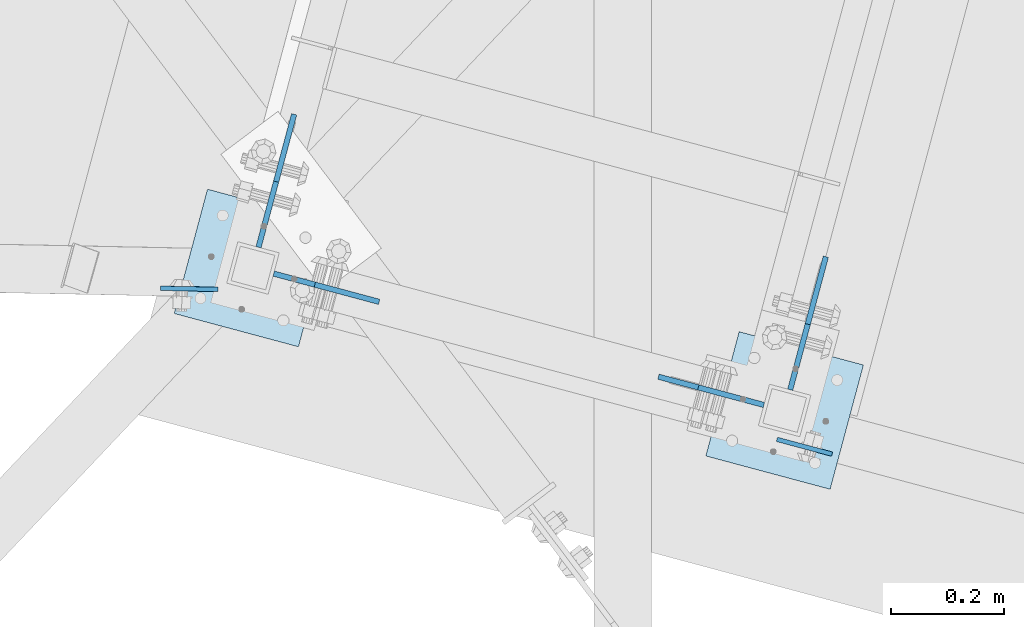
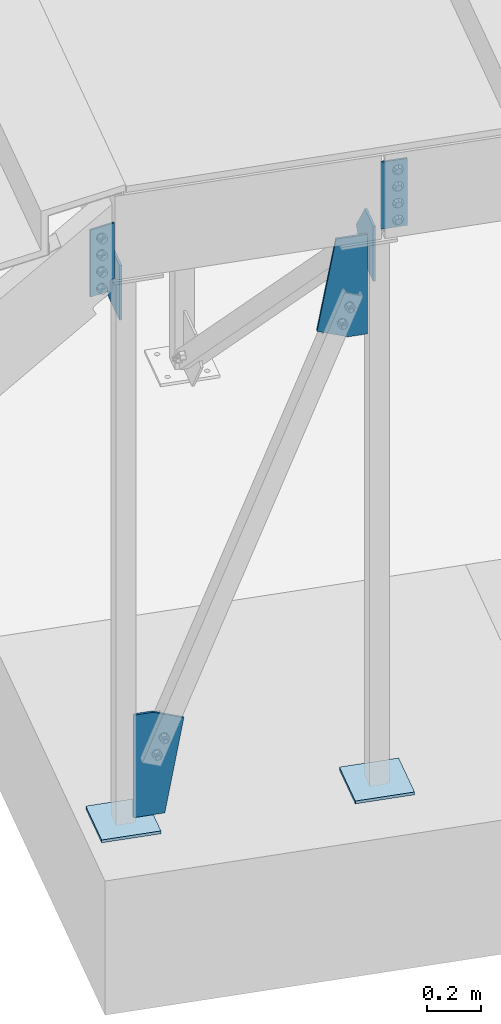
# One storey, part 1681 of 1763: 8 plates, 3 elements without a shape of their own.
"""IFC2X3 building model written with IfcOpenShell, lengths in millimetres."""

from ifc_helpers import new_model, si_unit, frame, origin_with_axes, place, context, subcontext, project, spatial, faceted_brep, material, type_object, element, aggregate, save


model = new_model("IFC2X3")

# Units and contexts
model_context = context("Model", 3, precision=1e-05, world=origin_with_axes())
body_context = subcontext(model_context, "Body", "Model", "MODEL_VIEW")
ifc_project = project(units=[si_unit("LENGTHUNIT", "METRE", prefix="MILLI"), si_unit("AREAUNIT", "SQUARE_METRE"), si_unit("VOLUMEUNIT", "CUBIC_METRE"), si_unit("MASSUNIT", "GRAM", prefix="KILO"), si_unit("TIMEUNIT", "SECOND"), si_unit("PLANEANGLEUNIT", "RADIAN"), si_unit("SOLIDANGLEUNIT", "STERADIAN"), si_unit("THERMODYNAMICTEMPERATUREUNIT", "DEGREE_CELSIUS"), si_unit("LUMINOUSINTENSITYUNIT", "LUMEN")], contexts=[model_context])

# Site, building, storey
site_placement = place(None, origin_with_axes())
site = spatial("IfcSite", under=ifc_project, at=site_placement, CompositionType="ELEMENT")
building_placement = place(site_placement, origin_with_axes())
building = spatial("IfcBuilding", under=site, at=building_placement, Name="Undefined", CompositionType="ELEMENT")
storey_placement = place(building_placement, origin_with_axes())
storey = spatial("IfcBuildingStorey", under=building, at=storey_placement, Name="Undefined", CompositionType="ELEMENT", Elevation=0.0)

# Assembly, plates
assembly_1_placement = place(storey_placement, origin_with_axes())
assembly_1 = element("IfcElementAssembly", 1, at=assembly_1_placement, inside=storey, Name="FRAME", AssemblyPlace="NOTDEFINED", PredefinedType="RIGID_FRAME")
ifc_material = material(Name="STEEL/A36")
plate_type_1 = type_object("IfcPlateType", PredefinedType="NOTDEFINED")
plate_1_placement = place(assembly_1_placement, frame((-27414.7858049951, 60238.992412548, 2590.80000029845), z_axis=(0.965913267114843, -0.258865912030785, 0.0), x_axis=(0.0, 0.0, -1.0)))
plate_1 = element("IfcPlate", 2, at=plate_1_placement, type_object=plate_type_1, material=ifc_material, Name="PLATE", context=body_context, shape_type="Brep", body=[
    faceted_brep([(0.0, -3.96900000000096, 0.0), (-1.18234311230481e-11, -3.96900000000096, 101.599998474121), (-1.18234311230481e-11, 3.96900000000096, 101.599998474121), (0.0, 3.96900000000096, 0.0), (304.799987792969, -3.96900000000096, 101.599998474121), (304.799987792969, 3.96900000000096, 101.599998474121), (304.799987792969, -3.96900000000096, -3.63797880709171e-11), (304.799987792969, 3.96900000000096, -3.63797880709171e-11)], [[[0, 1, 2, 3]], [[1, 4, 5, 2]], [[4, 6, 7, 5]], [[6, 0, 3, 7]], [[5, 7, 3, 2]], [[6, 4, 1, 0]]]),
])
plate_type_2 = type_object("IfcPlateType", PredefinedType="NOTDEFINED")
plate_2_placement = place(assembly_1_placement, frame((-28407.7357650568, 60505.3834172894, 2502.81193964552), z_axis=(-0.999800136337928, 0.0199919170066424, -0.000103116735640924), x_axis=(0.000111453000032564, 0.000415868000126109, -0.999999907316013)))
plate_2 = element("IfcPlate", 3, at=plate_2_placement, type_object=plate_type_2, material=ifc_material, Name="PLATE", context=body_context, shape_type="Brep", body=[
    faceted_brep([(254.931486313912, -3.96899999968446, 3.09228198602796e-10), (254.931020348674, 3.96900000030291, 3.20142135024071e-10), (254.908537894189, 3.96900000033202, 12.5064842653228), (254.909003857889, -3.9689999996699, 12.5064851036404), (255.387677638546, 3.96900000033929, 14.9377382974162), (255.388143602246, -3.96899999966263, 14.9377391357375), (256.760868400506, 3.96900000033929, 17.0004836040862), (256.761334364206, -3.96899999965535, 17.0004844424075), (258.818991804242, 3.96900000034657, 18.3805919809965), (258.819457767941, -3.96899999964808, 18.3805928193142), (261.248623498701, 3.96900000034657, 18.8678915931378), (261.249089462401, -3.9689999996408, 18.8678924314554), (304.799987792991, -3.96899999959714, 18.935818548016), (304.799987792992, 3.96900000040478, 18.9358184364428), (0.0, -3.96900000000096, 0.0), (-4.54747350886464e-13, -3.96899999978632, 101.980705261267), (-4.54747350886464e-13, 3.9690000002156, 101.980705261274), (0.0, 3.96900000000096, 0.0), (304.799987793001, -3.96899999941525, 101.980705261667), (304.799987793002, 3.96900000058668, 101.980705261682)], [[[0, 1, 2, 3]], [[3, 2, 4, 5]], [[5, 4, 6, 7]], [[7, 6, 8, 9]], [[9, 8, 10, 11]], [[12, 11, 10, 13]], [[14, 15, 16, 17]], [[15, 18, 19, 16]], [[19, 18, 12, 13]], [[8, 6, 4, 2, 1, 17, 16, 19, 13, 10]], [[14, 17, 1, 0]], [[18, 15, 14, 0, 3, 5, 7, 9, 11, 12]]]),
])
aggregate(assembly_1, [plate_1, plate_2])

# Assembly, plate
assembly_2_placement = place(storey_placement, origin_with_axes())
assembly_2 = element("IfcElementAssembly", 4, at=assembly_2_placement, inside=storey, Name="COLUMN", AssemblyPlace="NOTDEFINED", PredefinedType="RIGID_FRAME")
plate_type_3 = type_object("IfcPlateType", PredefinedType="NOTDEFINED")
plate_3_placement = place(assembly_2_placement, frame((-28485.5584110489, 60462.6258543711, -260.350000028325), z_axis=(0.258819045079128, 0.965925826295336, 0.0), x_axis=(0.965925826295336, -0.25881904507913, 0.0)))
plate_3 = element("IfcPlate", 5, at=plate_3_placement, type_object=plate_type_3, material=ifc_material, Name="PLATE", context=body_context, shape_type="Brep", body=[
    faceted_brep([(0.0, -6.34999999999491, 1.45519152283669e-11), (0.0, -6.35000000001855, 228.600006104178), (0.0, 6.34999999996944, 228.600006104134), (0.0, 6.34999999999491, -2.91038304567337e-11), (228.600006103363, -6.34999999999999, 228.600006104673), (228.600006103363, 6.35000000000002, 228.600006104673), (228.600006103565, -6.34999999936554, -7.49423634260893e-10), (228.600006103557, 6.35000000064611, -7.13043846189976e-10)], [[[0, 1, 2, 3]], [[1, 4, 5, 2]], [[4, 6, 7, 5]], [[6, 0, 3, 7]], [[5, 7, 3, 2]], [[6, 4, 1, 0]]]),
])

# Assembly, plates
assembly_3_placement = place(storey_placement, origin_with_axes())
assembly_3 = element("IfcElementAssembly", 6, at=assembly_3_placement, inside=storey, Name="COLUMN", AssemblyPlace="NOTDEFINED", PredefinedType="RIGID_FRAME")
plate_4_placement = place(assembly_3_placement, frame((-27540.9918271409, 60209.4808790024, -260.350000028323), z_axis=(0.258819045079128, 0.965925826295336, 0.0), x_axis=(0.965925826295336, -0.25881904507913, 0.0)))
plate_4 = element("IfcPlate", 7, at=plate_4_placement, type_object=plate_type_3, material=ifc_material, Name="PLATE", context=body_context, shape_type="Brep", body=[
    faceted_brep([(0.0, -6.34999999999491, 1.45519152283669e-11), (0.0, -6.35000000001855, 228.600006104178), (0.0, 6.34999999996944, 228.600006104134), (0.0, 6.34999999999491, -2.91038304567337e-11), (228.600006103363, -6.34999999999999, 228.600006104673), (228.600006103363, 6.35000000000002, 228.600006104673), (228.600006103565, -6.34999999936554, -7.49423634260893e-10), (228.600006103557, 6.35000000064611, -7.13043846189976e-10)], [[[0, 1, 2, 3]], [[1, 4, 5, 2]], [[4, 6, 7, 5]], [[6, 0, 3, 7]], [[5, 7, 3, 2]], [[6, 4, 1, 0]]]),
])
plate_type_4 = type_object("IfcPlateType", PredefinedType="NOTDEFINED")
plate_5_placement = place(assembly_3_placement, frame((-27391.1407206985, 60327.1044859432, 1985.92065652224), z_axis=(0.25886591203079, 0.965913267114842, 0.0), x_axis=(0.0, 0.0, 1.0)))
plate_5 = element("IfcPlate", 8, at=plate_5_placement, type_object=plate_type_4, material=ifc_material, Name="PLATE", context=body_context, shape_type="Brep", body=[
    faceted_brep([(0.0, -4.76249999999982, 0.0), (0.0, -4.76249999979336, 160.097076415994), (0.0, 4.76250000020809, 160.097076415972), (0.0, 4.76249999999982, 0.0), (94.7557754516604, -4.76249999967695, 244.657028198184), (94.7557754516604, 4.76250000031723, 244.657028198177), (249.279342651367, -4.76249999984429, 120.650001525864), (249.279342651367, 4.76250000014988, 120.65000152585), (249.279342651367, -4.76250000000437, 2.18278728425503e-11), (249.279342651367, 4.76249999998981, 7.27595761418343e-12)], [[[0, 1, 2, 3]], [[1, 4, 5, 2]], [[4, 6, 7, 5]], [[6, 8, 9, 7]], [[8, 0, 3, 9]], [[5, 7, 9, 3, 2]], [[8, 6, 4, 1, 0]]]),
])

# Plate
plate_6_placement = place(assembly_2_placement, frame((-28335.7559551054, 60580.2624971764, 1985.82723406555), z_axis=(0.25886591203079, 0.965913267114842, 0.0), x_axis=(0.0, 0.0, 1.0)))
plate_6 = element("IfcPlate", 9, at=plate_6_placement, type_object=plate_type_4, material=ifc_material, Name="PLATE", context=body_context, shape_type="Brep", body=[
    faceted_brep([(0.0, -4.76249999999982, 0.0), (0.0, -4.76249999979336, 160.097076415994), (0.0, 4.76250000020809, 160.097076415972), (0.0, 4.76249999999982, 0.0), (94.7557754516604, -4.76249999967695, 244.657028198184), (94.7557754516604, 4.76250000031723, 244.657028198177), (249.372772216797, -4.76249999984429, 120.650001525864), (249.372772216797, 4.76250000014988, 120.65000152585), (249.372772216797, -4.76250000000437, 2.18278728425503e-11), (249.372772216797, 4.76249999998981, 7.27595761418343e-12)], [[[0, 1, 2, 3]], [[1, 4, 5, 2]], [[4, 6, 7, 5]], [[6, 8, 9, 7]], [[8, 0, 3, 9]], [[5, 7, 9, 3, 2]], [[8, 6, 4, 1, 0]]]),
])

plate_type_5 = type_object("IfcPlateType", PredefinedType="NOTDEFINED")
plate_7_placement = place(assembly_3_placement, frame((-27437.8318797441, 60300.0648521524, 2235.20000005471), z_axis=(-0.965913267114846, 0.258865912030774, 0.0), x_axis=(0.0, 0.0, -1.0)))
plate_7 = element("IfcPlate", 10, at=plate_7_placement, type_object=plate_type_5, material=ifc_material, Name="PLATE", context=body_context, shape_type="Brep", body=[
    faceted_brep([(0.0, -4.76249999999982, 0.0), (3.8198777474463e-11, -4.76249999978609, 120.649999999834), (3.45607986673713e-11, 4.76250000024447, 120.649999999841), (0.0, 4.76249999999982, 0.0), (406.560302734375, -4.76249999963329, 194.001922607138), (406.560302734375, 4.76250000039727, 194.001922607145), (452.793731689453, -4.76249999986612, 75.7163848875789), (452.793731689453, 4.76250000016444, 75.7163848875862), (452.793731689453, -4.76250000001164, -5.82076609134674e-11), (452.793731689453, 4.76250000001164, -5.0931703299284e-11)], [[[0, 1, 2, 3]], [[1, 4, 5, 2]], [[4, 6, 7, 5]], [[6, 8, 9, 7]], [[8, 0, 3, 9]], [[5, 7, 9, 3, 2]], [[8, 6, 4, 1, 0]]]),
])

aggregate(assembly_3, [plate_5, plate_7, plate_4])

plate_8_placement = place(assembly_2_placement, frame((-28308.7958723333, 60533.484246044, 211.751491455232), z_axis=(0.965913267114843, -0.258865912030785, 0.0), x_axis=(0.0, 0.0, -1.0)))
plate_8 = element("IfcPlate", 11, at=plate_8_placement, type_object=plate_type_5, material=ifc_material, Name="PLATE", context=body_context, shape_type="Brep", body=[
    faceted_brep([(0.0, -4.76249999999982, 0.0), (7.67386154620908e-13, -4.76249999985157, 75.7163848875716), (7.67386154620908e-13, 4.76250000017171, 75.7163848875789), (0.0, 4.76249999999982, 0.0), (46.2334365844727, -4.76249999962602, 194.001922607131), (46.2334365844727, 4.76250000040454, 194.001922607138), (465.751495361328, -4.76249999977153, 120.65000152569), (465.751495361328, 4.76250000025175, 120.650001525704), (465.751495361328, -4.76250000001164, -7.27595761418343e-12), (465.751495361328, 4.76250000002619, 0.0)], [[[0, 1, 2, 3]], [[1, 4, 5, 2]], [[4, 6, 7, 5]], [[6, 8, 9, 7]], [[8, 0, 3, 9]], [[5, 7, 9, 3, 2]], [[8, 6, 4, 1, 0]]]),
])

aggregate(assembly_2, [plate_8, plate_6, plate_3])

save(model, "model.ifc")
